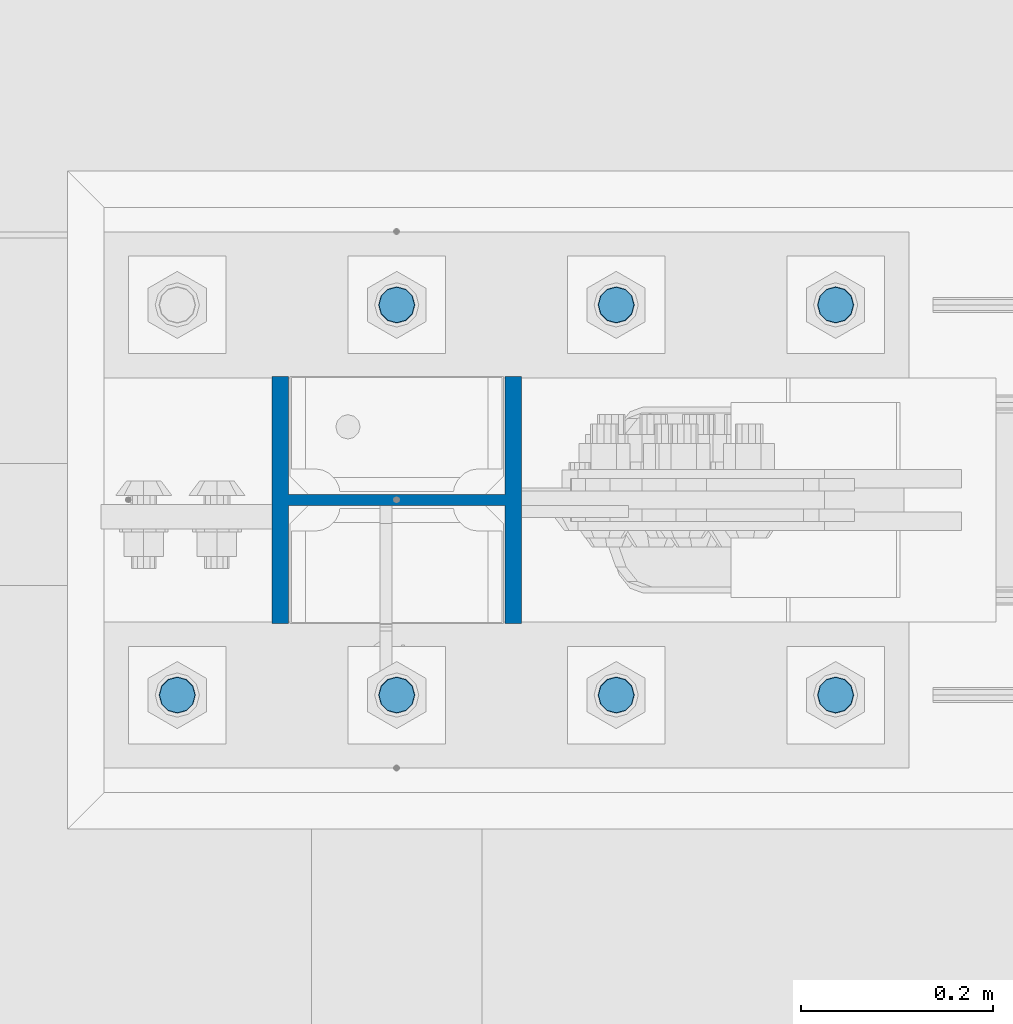
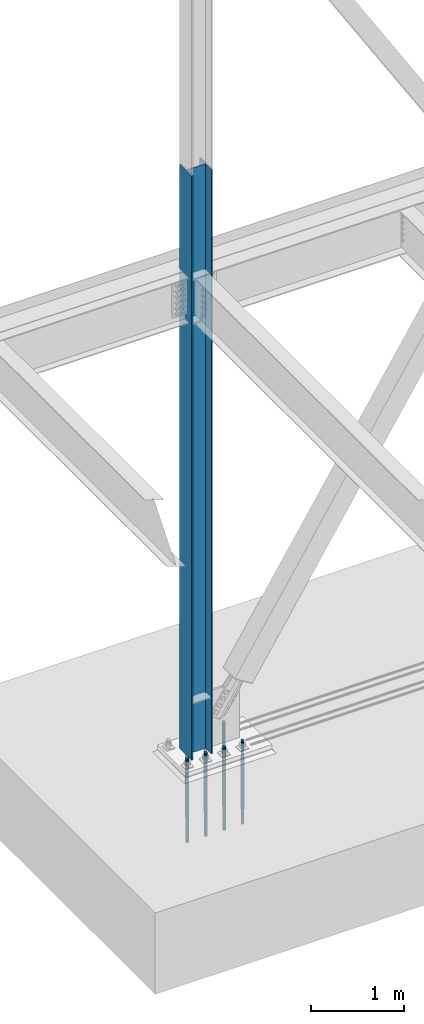
# One storey, part 1393 of 3843: 8 columns, 2 elements without a shape of their own.
"""IFC2X3 building model written with IfcOpenShell, lengths in millimetres."""

from ifc_helpers import new_model, si_unit, frame, origin_with_axes, place, context, subcontext, project, spatial, faceted_brep, material, type_object, element, aggregate, save


model = new_model("IFC2X3")

# Units and contexts
model_context = context("Model", 3, precision=1e-05, world=origin_with_axes())
body_context = subcontext(model_context, "Body", "Model", "MODEL_VIEW")
ifc_project = project(units=[si_unit("LENGTHUNIT", "METRE", prefix="MILLI"), si_unit("AREAUNIT", "SQUARE_METRE"), si_unit("VOLUMEUNIT", "CUBIC_METRE"), si_unit("MASSUNIT", "GRAM", prefix="KILO"), si_unit("TIMEUNIT", "SECOND"), si_unit("PLANEANGLEUNIT", "RADIAN"), si_unit("SOLIDANGLEUNIT", "STERADIAN"), si_unit("THERMODYNAMICTEMPERATUREUNIT", "DEGREE_CELSIUS"), si_unit("LUMINOUSINTENSITYUNIT", "LUMEN")], contexts=[model_context])

# Site, building, storey
site_placement = place(None, origin_with_axes())
site = spatial("IfcSite", under=ifc_project, at=site_placement, CompositionType="ELEMENT")
building_placement = place(site_placement, origin_with_axes())
building = spatial("IfcBuilding", under=site, at=building_placement, Name="Undefined", CompositionType="ELEMENT")
storey_placement = place(building_placement, origin_with_axes())
storey = spatial("IfcBuildingStorey", under=building, at=storey_placement, Name="Undefined", CompositionType="ELEMENT", Elevation=0.0)

# Assembly, column
assembly_1_placement = place(storey_placement, origin_with_axes())
assembly_1 = element("IfcElementAssembly", 1, at=assembly_1_placement, inside=storey, Name="COLUMN", AssemblyPlace="NOTDEFINED", PredefinedType="RIGID_FRAME")
ifc_material_1 = material(Name="STEEL/A992")
column_type_1 = type_object("IfcColumnType", Name="W10X60", PredefinedType="NOTDEFINED")
column_1_placement = place(assembly_1_placement, frame((22860.0, 104559.1, 30022.8), z_axis=(-1.0, 0.0, 0.0), x_axis=(0.0, 0.0, 1.0)))
column_1 = element("IfcColumn", 2, at=column_1_placement, type_object=column_type_1, material=ifc_material_1, Name="COLUMN", ObjectType="W10X60", context=body_context, shape_type="Brep", body=[
    faceted_brep([(101.599999999999, 128.587499999994, -130.174999999999), (101.599999999999, 128.587499999994, -112.712500000001), (7772.4, 128.587499999994, -112.712500000001), (7772.4, 128.587499999994, -130.174999999999), (101.599999999999, 5.55624999999418, -112.712500000001), (7772.4, 5.55624999999418, -112.712500000001), (101.599999999999, 5.55624999999418, 112.712500000001), (7772.4, 5.55624999999418, 112.712500000001), (101.599999999999, 128.587499999994, 112.712500000001), (7772.4, 128.587499999994, 112.712500000001), (101.599999999999, 128.587499999994, 130.174999999999), (7772.4, 128.587499999994, 130.174999999999), (101.599999999999, -128.587499999994, 130.174999999999), (7772.4, -128.587499999994, 130.174999999999), (101.599999999999, -128.587499999994, 112.712500000001), (7772.4, -128.587499999994, 112.712500000001), (101.599999999999, -5.55624999999418, 112.712500000001), (7772.4, -5.55624999999418, 112.712500000001), (101.599999999999, -5.55624999999418, -112.712500000001), (7772.4, -5.55624999999418, -112.712500000001), (101.599999999999, -128.587499999994, -112.712500000001), (7772.4, -128.587499999994, -112.712500000001), (101.599999999999, -128.587499999994, -130.174999999999), (7772.4, -128.587499999994, -130.174999999999)], [[[0, 1, 2, 3]], [[1, 4, 5, 2]], [[4, 6, 7, 5]], [[6, 8, 9, 7]], [[8, 10, 11, 9]], [[10, 12, 13, 11]], [[12, 14, 15, 13]], [[14, 16, 17, 15]], [[16, 18, 19, 17]], [[18, 20, 21, 19]], [[20, 22, 23, 21]], [[22, 0, 3, 23]], [[5, 7, 9, 11, 13, 15, 17, 19, 21, 23, 3, 2]], [[22, 20, 18, 16, 14, 12, 10, 8, 6, 4, 1, 0]]]),
])
aggregate(assembly_1, [column_1])

# Assembly, columns
assembly_2_placement = place(storey_placement, origin_with_axes())
assembly_2 = element("IfcElementAssembly", 3, at=assembly_2_placement, inside=storey, Name="TEMPLATE", AssemblyPlace="NOTDEFINED", PredefinedType="RIGID_FRAME")
ifc_material_2 = material(Name="Undefined/F1554-GR.55")
column_type_2 = type_object("IfcColumnType", PredefinedType="NOTDEFINED")
column_2_placement = place(assembly_2_placement, frame((23317.2, 104355.9, 30022.8), z_axis=(1.0, 0.0, 0.0), x_axis=(0.0, 0.0, -1.0)))
column_2 = element("IfcColumn", 4, at=column_2_placement, type_object=column_type_2, material=ifc_material_2, Name="ANCHOR_ROD", context=body_context, shape_type="Brep", body=[
    faceted_brep([(-209.549999999999, -16.0214699700155, 9.25), (-209.549999999999, -9.25, 16.0214699700118), (-209.549999999999, 0.0, 18.5), (-209.549999999999, 9.25, 16.0214699700118), (-209.549999999999, 16.0214699700155, 9.25), (-209.549999999999, 18.5, 0.0), (-209.549999999999, 16.0214699700155, -9.25), (-209.549999999999, 9.25, -16.0214699700118), (-209.549999999999, 0.0, -18.5), (-209.549999999999, -9.25, -16.0214699700118), (-209.549999999999, -16.0214699700155, -9.25), (-209.549999999999, -18.5, 0.0), (0.0, 18.5, 0.0), (0.0, 16.0214699700118, -9.25), (0.0, 9.25, -16.0214699700155), (0.0, 0.0, -18.5), (0.0, -9.25, -16.0214699700155), (0.0, -16.0214699700118, -9.25), (0.0, -18.5, 0.0), (0.0, -16.0214699700118, 9.25), (0.0, -9.25, 16.0214699700155), (0.0, 0.0, 18.5), (0.0, 9.25, 16.0214699700155), (0.0, 16.0214699700118, 9.25), (0.0, -16.4977839420972, 9.52500000000146), (0.0, -9.52500000000146, 16.4977839420972), (0.0, 0.0, 19.0499989999989), (0.0, 9.52500000000146, 16.4977839420972), (0.0, 16.4977839420972, 9.52500000000146), (0.0, 19.0500000000029, 0.0), (0.0, 16.4977839420972, -9.52500000000146), (0.0, 9.52500000000146, -16.4977839420972), (0.0, 0.0, -19.0499989999989), (0.0, -9.52500000000146, -16.4977839420972), (0.0, -16.4977839420972, -9.52500000000146), (0.0, -19.0500000000029, 0.0), (698.5, -19.0499999999993, 0.0), (698.5, -16.4977839420935, 9.52499999999418), (698.5, -9.52500000000146, 16.4977839420899), (698.5, 0.0, 19.0500000000029), (698.5, 9.52500000000146, 16.4977839420899), (698.5, 16.4977839420935, 9.52499999999418), (698.5, 19.0499999999993, 0.0), (698.5, 16.4977839420935, -9.52499999999418), (698.5, 9.52500000000146, -16.4977839420899), (698.5, 0.0, -19.0500000000029), (698.5, -9.52500000000146, -16.4977839420899), (698.5, -16.4977839420935, -9.52499999999418), (698.5, -9.25, 16.0214699700155), (698.5, 0.0, 18.5), (698.5, 9.25, 16.0214699700155), (698.5, 16.0214699700118, 9.25), (698.5, 18.5, 0.0), (698.5, 16.0214699700118, -9.25), (698.5, 9.25, -16.0214699700155), (698.5, 0.0, -18.5), (698.5, -9.25, -16.0214699700155), (698.5, -16.0214699700118, -9.25), (698.5, -18.5, 0.0), (698.5, -16.0214699700118, 9.25), (889.0, -9.25, -16.0214699700155), (889.0, 0.0, -18.5), (889.0, 9.25, -16.0214699700155), (889.0, 16.0214699700118, -9.25), (889.0, 18.5, 0.0), (889.0, 16.0214699700118, 9.25), (889.0, 9.25, 16.0214699700155), (889.0, 0.0, 18.5), (889.0, -9.25, 16.0214699700155), (889.0, -16.0214699700118, 9.25), (889.0, -18.5, 0.0), (889.0, -16.0214699700118, -9.25)], [[[0, 1, 2, 3, 4, 5, 6, 7, 8, 9, 10, 11]], [[6, 5, 12, 13]], [[7, 6, 13, 14]], [[8, 7, 14, 15]], [[9, 8, 15, 16]], [[10, 9, 16, 17]], [[11, 10, 17, 18]], [[0, 11, 18, 19]], [[1, 0, 19, 20]], [[2, 1, 20, 21]], [[3, 2, 21, 22]], [[4, 3, 22, 23]], [[5, 4, 23, 12]], [[24, 25, 26, 27, 28, 29, 30, 31, 32, 33, 34, 35], [22, 21, 20, 19, 18, 17, 16, 15, 14, 13, 12, 23]], [[24, 35, 36, 37]], [[25, 24, 37, 38]], [[26, 25, 38, 39]], [[27, 26, 39, 40]], [[28, 27, 40, 41]], [[29, 28, 41, 42]], [[30, 29, 42, 43]], [[31, 30, 43, 44]], [[32, 31, 44, 45]], [[33, 32, 45, 46]], [[34, 33, 46, 47]], [[35, 34, 47, 36]], [[46, 45, 44, 43, 42, 41, 40, 39, 38, 37, 36, 47], [48, 49, 50, 51, 52, 53, 54, 55, 56, 57, 58, 59]], [[60, 61, 62, 63, 64, 65, 66, 67, 68, 69, 70, 71]], [[68, 67, 49, 48]], [[69, 68, 48, 59]], [[70, 69, 59, 58]], [[71, 70, 58, 57]], [[60, 71, 57, 56]], [[61, 60, 56, 55]], [[62, 61, 55, 54]], [[63, 62, 54, 53]], [[64, 63, 53, 52]], [[65, 64, 52, 51]], [[66, 65, 51, 50]], [[67, 66, 50, 49]]]),
])
column_3_placement = place(assembly_2_placement, frame((23317.2, 104762.3, 30022.8), z_axis=(-1.0, 0.0, 0.0), x_axis=(0.0, 0.0, -1.0)))
column_3 = element("IfcColumn", 5, at=column_3_placement, type_object=column_type_2, material=ifc_material_2, Name="ANCHOR_ROD", context=body_context, shape_type="Brep", body=[
    faceted_brep([(-209.549999999999, -16.0214699700155, 9.25), (-209.549999999999, -9.25, 16.0214699700118), (-209.549999999999, 0.0, 18.5), (-209.549999999999, 9.25, 16.0214699700118), (-209.549999999999, 16.0214699700155, 9.25), (-209.549999999999, 18.5, 0.0), (-209.549999999999, 16.0214699700155, -9.25), (-209.549999999999, 9.25, -16.0214699700118), (-209.549999999999, 0.0, -18.5), (-209.549999999999, -9.25, -16.0214699700118), (-209.549999999999, -16.0214699700155, -9.25), (-209.549999999999, -18.5, 0.0), (0.0, 18.5, 0.0), (0.0, 16.0214699700118, -9.25), (0.0, 9.25, -16.0214699700155), (0.0, 0.0, -18.5), (0.0, -9.25, -16.0214699700155), (0.0, -16.0214699700118, -9.25), (0.0, -18.5, 0.0), (0.0, -16.0214699700118, 9.25), (0.0, -9.25, 16.0214699700155), (0.0, 0.0, 18.5), (0.0, 9.25, 16.0214699700155), (0.0, 16.0214699700118, 9.25), (0.0, -16.4977839420972, 9.52500000000146), (0.0, -9.52500000000146, 16.4977839420972), (0.0, 0.0, 19.0499989999989), (0.0, 9.52500000000146, 16.4977839420972), (0.0, 16.4977839420972, 9.52500000000146), (0.0, 19.0500000000029, 0.0), (0.0, 16.4977839420972, -9.52500000000146), (0.0, 9.52500000000146, -16.4977839420972), (0.0, 0.0, -19.0499989999989), (0.0, -9.52500000000146, -16.4977839420972), (0.0, -16.4977839420972, -9.52500000000146), (0.0, -19.0500000000029, 0.0), (698.5, -19.0499999999993, 0.0), (698.5, -16.4977839420935, 9.52499999999418), (698.5, -9.52500000000146, 16.4977839420899), (698.5, 0.0, 19.0500000000029), (698.5, 9.52500000000146, 16.4977839420899), (698.5, 16.4977839420935, 9.52499999999418), (698.5, 19.0499999999993, 0.0), (698.5, 16.4977839420935, -9.52499999999418), (698.5, 9.52500000000146, -16.4977839420899), (698.5, 0.0, -19.0500000000029), (698.5, -9.52500000000146, -16.4977839420899), (698.5, -16.4977839420935, -9.52499999999418), (698.5, -9.25, 16.0214699700155), (698.5, 0.0, 18.5), (698.5, 9.25, 16.0214699700155), (698.5, 16.0214699700118, 9.25), (698.5, 18.5, 0.0), (698.5, 16.0214699700118, -9.25), (698.5, 9.25, -16.0214699700155), (698.5, 0.0, -18.5), (698.5, -9.25, -16.0214699700155), (698.5, -16.0214699700118, -9.25), (698.5, -18.5, 0.0), (698.5, -16.0214699700118, 9.25), (889.0, -9.25, -16.0214699700155), (889.0, 0.0, -18.5), (889.0, 9.25, -16.0214699700155), (889.0, 16.0214699700118, -9.25), (889.0, 18.5, 0.0), (889.0, 16.0214699700118, 9.25), (889.0, 9.25, 16.0214699700155), (889.0, 0.0, 18.5), (889.0, -9.25, 16.0214699700155), (889.0, -16.0214699700118, 9.25), (889.0, -18.5, 0.0), (889.0, -16.0214699700118, -9.25)], [[[0, 1, 2, 3, 4, 5, 6, 7, 8, 9, 10, 11]], [[6, 5, 12, 13]], [[7, 6, 13, 14]], [[8, 7, 14, 15]], [[9, 8, 15, 16]], [[10, 9, 16, 17]], [[11, 10, 17, 18]], [[0, 11, 18, 19]], [[1, 0, 19, 20]], [[2, 1, 20, 21]], [[3, 2, 21, 22]], [[4, 3, 22, 23]], [[5, 4, 23, 12]], [[24, 25, 26, 27, 28, 29, 30, 31, 32, 33, 34, 35], [22, 21, 20, 19, 18, 17, 16, 15, 14, 13, 12, 23]], [[24, 35, 36, 37]], [[25, 24, 37, 38]], [[26, 25, 38, 39]], [[27, 26, 39, 40]], [[28, 27, 40, 41]], [[29, 28, 41, 42]], [[30, 29, 42, 43]], [[31, 30, 43, 44]], [[32, 31, 44, 45]], [[33, 32, 45, 46]], [[34, 33, 46, 47]], [[35, 34, 47, 36]], [[46, 45, 44, 43, 42, 41, 40, 39, 38, 37, 36, 47], [48, 49, 50, 51, 52, 53, 54, 55, 56, 57, 58, 59]], [[60, 61, 62, 63, 64, 65, 66, 67, 68, 69, 70, 71]], [[68, 67, 49, 48]], [[69, 68, 48, 59]], [[70, 69, 59, 58]], [[71, 70, 58, 57]], [[60, 71, 57, 56]], [[61, 60, 56, 55]], [[62, 61, 55, 54]], [[63, 62, 54, 53]], [[64, 63, 53, 52]], [[65, 64, 52, 51]], [[66, 65, 51, 50]], [[67, 66, 50, 49]]]),
])
column_4_placement = place(assembly_2_placement, frame((23088.6, 104355.9, 30022.8), z_axis=(1.0, 0.0, 0.0), x_axis=(0.0, 0.0, -1.0)))
column_4 = element("IfcColumn", 6, at=column_4_placement, type_object=column_type_2, material=ifc_material_2, Name="ANCHOR_ROD", context=body_context, shape_type="Brep", body=[
    faceted_brep([(-209.549999999999, -16.0214699700155, 9.25), (-209.549999999999, -9.25, 16.0214699700118), (-209.549999999999, 0.0, 18.5), (-209.549999999999, 9.25, 16.0214699700118), (-209.549999999999, 16.0214699700155, 9.25), (-209.549999999999, 18.5, 0.0), (-209.549999999999, 16.0214699700155, -9.25), (-209.549999999999, 9.25, -16.0214699700118), (-209.549999999999, 0.0, -18.5), (-209.549999999999, -9.25, -16.0214699700118), (-209.549999999999, -16.0214699700155, -9.25), (-209.549999999999, -18.5, 0.0), (0.0, 18.5, 0.0), (0.0, 16.0214699700118, -9.25), (0.0, 9.25, -16.0214699700155), (0.0, 0.0, -18.5), (0.0, -9.25, -16.0214699700155), (0.0, -16.0214699700118, -9.25), (0.0, -18.5, 0.0), (0.0, -16.0214699700118, 9.25), (0.0, -9.25, 16.0214699700155), (0.0, 0.0, 18.5), (0.0, 9.25, 16.0214699700155), (0.0, 16.0214699700118, 9.25), (0.0, -16.4977839420972, 9.52500000000146), (0.0, -9.52500000000146, 16.4977839420972), (0.0, 0.0, 19.0499989999989), (0.0, 9.52500000000146, 16.4977839420972), (0.0, 16.4977839420972, 9.52500000000146), (0.0, 19.0500000000029, 0.0), (0.0, 16.4977839420972, -9.52500000000146), (0.0, 9.52500000000146, -16.4977839420972), (0.0, 0.0, -19.0499989999989), (0.0, -9.52500000000146, -16.4977839420972), (0.0, -16.4977839420972, -9.52500000000146), (0.0, -19.0500000000029, 0.0), (698.5, -19.0499999999993, 0.0), (698.5, -16.4977839420935, 9.52499999999418), (698.5, -9.52500000000146, 16.4977839420899), (698.5, 0.0, 19.0500000000029), (698.5, 9.52500000000146, 16.4977839420899), (698.5, 16.4977839420935, 9.52499999999418), (698.5, 19.0499999999993, 0.0), (698.5, 16.4977839420935, -9.52499999999418), (698.5, 9.52500000000146, -16.4977839420899), (698.5, 0.0, -19.0500000000029), (698.5, -9.52500000000146, -16.4977839420899), (698.5, -16.4977839420935, -9.52499999999418), (698.5, -9.25, 16.0214699700155), (698.5, 0.0, 18.5), (698.5, 9.25, 16.0214699700155), (698.5, 16.0214699700118, 9.25), (698.5, 18.5, 0.0), (698.5, 16.0214699700118, -9.25), (698.5, 9.25, -16.0214699700155), (698.5, 0.0, -18.5), (698.5, -9.25, -16.0214699700155), (698.5, -16.0214699700118, -9.25), (698.5, -18.5, 0.0), (698.5, -16.0214699700118, 9.25), (889.0, -9.25, -16.0214699700155), (889.0, 0.0, -18.5), (889.0, 9.25, -16.0214699700155), (889.0, 16.0214699700118, -9.25), (889.0, 18.5, 0.0), (889.0, 16.0214699700118, 9.25), (889.0, 9.25, 16.0214699700155), (889.0, 0.0, 18.5), (889.0, -9.25, 16.0214699700155), (889.0, -16.0214699700118, 9.25), (889.0, -18.5, 0.0), (889.0, -16.0214699700118, -9.25)], [[[0, 1, 2, 3, 4, 5, 6, 7, 8, 9, 10, 11]], [[6, 5, 12, 13]], [[7, 6, 13, 14]], [[8, 7, 14, 15]], [[9, 8, 15, 16]], [[10, 9, 16, 17]], [[11, 10, 17, 18]], [[0, 11, 18, 19]], [[1, 0, 19, 20]], [[2, 1, 20, 21]], [[3, 2, 21, 22]], [[4, 3, 22, 23]], [[5, 4, 23, 12]], [[24, 25, 26, 27, 28, 29, 30, 31, 32, 33, 34, 35], [22, 21, 20, 19, 18, 17, 16, 15, 14, 13, 12, 23]], [[24, 35, 36, 37]], [[25, 24, 37, 38]], [[26, 25, 38, 39]], [[27, 26, 39, 40]], [[28, 27, 40, 41]], [[29, 28, 41, 42]], [[30, 29, 42, 43]], [[31, 30, 43, 44]], [[32, 31, 44, 45]], [[33, 32, 45, 46]], [[34, 33, 46, 47]], [[35, 34, 47, 36]], [[46, 45, 44, 43, 42, 41, 40, 39, 38, 37, 36, 47], [48, 49, 50, 51, 52, 53, 54, 55, 56, 57, 58, 59]], [[60, 61, 62, 63, 64, 65, 66, 67, 68, 69, 70, 71]], [[68, 67, 49, 48]], [[69, 68, 48, 59]], [[70, 69, 59, 58]], [[71, 70, 58, 57]], [[60, 71, 57, 56]], [[61, 60, 56, 55]], [[62, 61, 55, 54]], [[63, 62, 54, 53]], [[64, 63, 53, 52]], [[65, 64, 52, 51]], [[66, 65, 51, 50]], [[67, 66, 50, 49]]]),
])
column_5_placement = place(assembly_2_placement, frame((23088.6, 104762.3, 30022.8), z_axis=(-1.0, 0.0, 0.0), x_axis=(0.0, 0.0, -1.0)))
column_5 = element("IfcColumn", 7, at=column_5_placement, type_object=column_type_2, material=ifc_material_2, Name="ANCHOR_ROD", context=body_context, shape_type="Brep", body=[
    faceted_brep([(-209.549999999999, -16.0214699700155, 9.25), (-209.549999999999, -9.25, 16.0214699700118), (-209.549999999999, 0.0, 18.5), (-209.549999999999, 9.25, 16.0214699700118), (-209.549999999999, 16.0214699700155, 9.25), (-209.549999999999, 18.5, 0.0), (-209.549999999999, 16.0214699700155, -9.25), (-209.549999999999, 9.25, -16.0214699700118), (-209.549999999999, 0.0, -18.5), (-209.549999999999, -9.25, -16.0214699700118), (-209.549999999999, -16.0214699700155, -9.25), (-209.549999999999, -18.5, 0.0), (0.0, 18.5, 0.0), (0.0, 16.0214699700118, -9.25), (0.0, 9.25, -16.0214699700155), (0.0, 0.0, -18.5), (0.0, -9.25, -16.0214699700155), (0.0, -16.0214699700118, -9.25), (0.0, -18.5, 0.0), (0.0, -16.0214699700118, 9.25), (0.0, -9.25, 16.0214699700155), (0.0, 0.0, 18.5), (0.0, 9.25, 16.0214699700155), (0.0, 16.0214699700118, 9.25), (0.0, -16.4977839420972, 9.52500000000146), (0.0, -9.52500000000146, 16.4977839420972), (0.0, 0.0, 19.0499989999989), (0.0, 9.52500000000146, 16.4977839420972), (0.0, 16.4977839420972, 9.52500000000146), (0.0, 19.0500000000029, 0.0), (0.0, 16.4977839420972, -9.52500000000146), (0.0, 9.52500000000146, -16.4977839420972), (0.0, 0.0, -19.0499989999989), (0.0, -9.52500000000146, -16.4977839420972), (0.0, -16.4977839420972, -9.52500000000146), (0.0, -19.0500000000029, 0.0), (698.5, -19.0499999999993, 0.0), (698.5, -16.4977839420935, 9.52499999999418), (698.5, -9.52500000000146, 16.4977839420899), (698.5, 0.0, 19.0500000000029), (698.5, 9.52500000000146, 16.4977839420899), (698.5, 16.4977839420935, 9.52499999999418), (698.5, 19.0499999999993, 0.0), (698.5, 16.4977839420935, -9.52499999999418), (698.5, 9.52500000000146, -16.4977839420899), (698.5, 0.0, -19.0500000000029), (698.5, -9.52500000000146, -16.4977839420899), (698.5, -16.4977839420935, -9.52499999999418), (698.5, -9.25, 16.0214699700155), (698.5, 0.0, 18.5), (698.5, 9.25, 16.0214699700155), (698.5, 16.0214699700118, 9.25), (698.5, 18.5, 0.0), (698.5, 16.0214699700118, -9.25), (698.5, 9.25, -16.0214699700155), (698.5, 0.0, -18.5), (698.5, -9.25, -16.0214699700155), (698.5, -16.0214699700118, -9.25), (698.5, -18.5, 0.0), (698.5, -16.0214699700118, 9.25), (889.0, -9.25, -16.0214699700155), (889.0, 0.0, -18.5), (889.0, 9.25, -16.0214699700155), (889.0, 16.0214699700118, -9.25), (889.0, 18.5, 0.0), (889.0, 16.0214699700118, 9.25), (889.0, 9.25, 16.0214699700155), (889.0, 0.0, 18.5), (889.0, -9.25, 16.0214699700155), (889.0, -16.0214699700118, 9.25), (889.0, -18.5, 0.0), (889.0, -16.0214699700118, -9.25)], [[[0, 1, 2, 3, 4, 5, 6, 7, 8, 9, 10, 11]], [[6, 5, 12, 13]], [[7, 6, 13, 14]], [[8, 7, 14, 15]], [[9, 8, 15, 16]], [[10, 9, 16, 17]], [[11, 10, 17, 18]], [[0, 11, 18, 19]], [[1, 0, 19, 20]], [[2, 1, 20, 21]], [[3, 2, 21, 22]], [[4, 3, 22, 23]], [[5, 4, 23, 12]], [[24, 25, 26, 27, 28, 29, 30, 31, 32, 33, 34, 35], [22, 21, 20, 19, 18, 17, 16, 15, 14, 13, 12, 23]], [[24, 35, 36, 37]], [[25, 24, 37, 38]], [[26, 25, 38, 39]], [[27, 26, 39, 40]], [[28, 27, 40, 41]], [[29, 28, 41, 42]], [[30, 29, 42, 43]], [[31, 30, 43, 44]], [[32, 31, 44, 45]], [[33, 32, 45, 46]], [[34, 33, 46, 47]], [[35, 34, 47, 36]], [[46, 45, 44, 43, 42, 41, 40, 39, 38, 37, 36, 47], [48, 49, 50, 51, 52, 53, 54, 55, 56, 57, 58, 59]], [[60, 61, 62, 63, 64, 65, 66, 67, 68, 69, 70, 71]], [[68, 67, 49, 48]], [[69, 68, 48, 59]], [[70, 69, 59, 58]], [[71, 70, 58, 57]], [[60, 71, 57, 56]], [[61, 60, 56, 55]], [[62, 61, 55, 54]], [[63, 62, 54, 53]], [[64, 63, 53, 52]], [[65, 64, 52, 51]], [[66, 65, 51, 50]], [[67, 66, 50, 49]]]),
])
column_6_placement = place(assembly_2_placement, frame((22860.0, 104355.9, 30022.8), z_axis=(1.0, 0.0, 0.0), x_axis=(0.0, 0.0, -1.0)))
column_6 = element("IfcColumn", 8, at=column_6_placement, type_object=column_type_2, material=ifc_material_2, Name="ANCHOR_ROD", context=body_context, shape_type="Brep", body=[
    faceted_brep([(-209.549999999999, -16.0214699700155, 9.25), (-209.549999999999, -9.25, 16.0214699700118), (-209.549999999999, 0.0, 18.5), (-209.549999999999, 9.25, 16.0214699700118), (-209.549999999999, 16.0214699700155, 9.25), (-209.549999999999, 18.5, 0.0), (-209.549999999999, 16.0214699700155, -9.25), (-209.549999999999, 9.25, -16.0214699700118), (-209.549999999999, 0.0, -18.5), (-209.549999999999, -9.25, -16.0214699700118), (-209.549999999999, -16.0214699700155, -9.25), (-209.549999999999, -18.5, 0.0), (0.0, 18.5, 0.0), (0.0, 16.0214699700118, -9.25), (0.0, 9.25, -16.0214699700155), (0.0, 0.0, -18.5), (0.0, -9.25, -16.0214699700155), (0.0, -16.0214699700118, -9.25), (0.0, -18.5, 0.0), (0.0, -16.0214699700118, 9.25), (0.0, -9.25, 16.0214699700155), (0.0, 0.0, 18.5), (0.0, 9.25, 16.0214699700155), (0.0, 16.0214699700118, 9.25), (0.0, -16.4977839420972, 9.52500000000146), (0.0, -9.52500000000146, 16.4977839420972), (0.0, 0.0, 19.0499989999989), (0.0, 9.52500000000146, 16.4977839420972), (0.0, 16.4977839420972, 9.52500000000146), (0.0, 19.0500000000029, 0.0), (0.0, 16.4977839420972, -9.52500000000146), (0.0, 9.52500000000146, -16.4977839420972), (0.0, 0.0, -19.0499989999989), (0.0, -9.52500000000146, -16.4977839420972), (0.0, -16.4977839420972, -9.52500000000146), (0.0, -19.0500000000029, 0.0), (698.5, -19.0499999999993, 0.0), (698.5, -16.4977839420935, 9.52499999999418), (698.5, -9.52500000000146, 16.4977839420899), (698.5, 0.0, 19.0500000000029), (698.5, 9.52500000000146, 16.4977839420899), (698.5, 16.4977839420935, 9.52499999999418), (698.5, 19.0499999999993, 0.0), (698.5, 16.4977839420935, -9.52499999999418), (698.5, 9.52500000000146, -16.4977839420899), (698.5, 0.0, -19.0500000000029), (698.5, -9.52500000000146, -16.4977839420899), (698.5, -16.4977839420935, -9.52499999999418), (698.5, -9.25, 16.0214699700155), (698.5, 0.0, 18.5), (698.5, 9.25, 16.0214699700155), (698.5, 16.0214699700118, 9.25), (698.5, 18.5, 0.0), (698.5, 16.0214699700118, -9.25), (698.5, 9.25, -16.0214699700155), (698.5, 0.0, -18.5), (698.5, -9.25, -16.0214699700155), (698.5, -16.0214699700118, -9.25), (698.5, -18.5, 0.0), (698.5, -16.0214699700118, 9.25), (889.0, -9.25, -16.0214699700155), (889.0, 0.0, -18.5), (889.0, 9.25, -16.0214699700155), (889.0, 16.0214699700118, -9.25), (889.0, 18.5, 0.0), (889.0, 16.0214699700118, 9.25), (889.0, 9.25, 16.0214699700155), (889.0, 0.0, 18.5), (889.0, -9.25, 16.0214699700155), (889.0, -16.0214699700118, 9.25), (889.0, -18.5, 0.0), (889.0, -16.0214699700118, -9.25)], [[[0, 1, 2, 3, 4, 5, 6, 7, 8, 9, 10, 11]], [[6, 5, 12, 13]], [[7, 6, 13, 14]], [[8, 7, 14, 15]], [[9, 8, 15, 16]], [[10, 9, 16, 17]], [[11, 10, 17, 18]], [[0, 11, 18, 19]], [[1, 0, 19, 20]], [[2, 1, 20, 21]], [[3, 2, 21, 22]], [[4, 3, 22, 23]], [[5, 4, 23, 12]], [[24, 25, 26, 27, 28, 29, 30, 31, 32, 33, 34, 35], [22, 21, 20, 19, 18, 17, 16, 15, 14, 13, 12, 23]], [[24, 35, 36, 37]], [[25, 24, 37, 38]], [[26, 25, 38, 39]], [[27, 26, 39, 40]], [[28, 27, 40, 41]], [[29, 28, 41, 42]], [[30, 29, 42, 43]], [[31, 30, 43, 44]], [[32, 31, 44, 45]], [[33, 32, 45, 46]], [[34, 33, 46, 47]], [[35, 34, 47, 36]], [[46, 45, 44, 43, 42, 41, 40, 39, 38, 37, 36, 47], [48, 49, 50, 51, 52, 53, 54, 55, 56, 57, 58, 59]], [[60, 61, 62, 63, 64, 65, 66, 67, 68, 69, 70, 71]], [[68, 67, 49, 48]], [[69, 68, 48, 59]], [[70, 69, 59, 58]], [[71, 70, 58, 57]], [[60, 71, 57, 56]], [[61, 60, 56, 55]], [[62, 61, 55, 54]], [[63, 62, 54, 53]], [[64, 63, 53, 52]], [[65, 64, 52, 51]], [[66, 65, 51, 50]], [[67, 66, 50, 49]]]),
])
column_7_placement = place(assembly_2_placement, frame((22860.0, 104762.3, 30022.8), z_axis=(-1.0, 0.0, 0.0), x_axis=(0.0, 0.0, -1.0)))
column_7 = element("IfcColumn", 9, at=column_7_placement, type_object=column_type_2, material=ifc_material_2, Name="ANCHOR_ROD", context=body_context, shape_type="Brep", body=[
    faceted_brep([(-209.549999999999, -16.0214699700155, 9.25), (-209.549999999999, -9.25, 16.0214699700118), (-209.549999999999, 0.0, 18.5), (-209.549999999999, 9.25, 16.0214699700118), (-209.549999999999, 16.0214699700155, 9.25), (-209.549999999999, 18.5, 0.0), (-209.549999999999, 16.0214699700155, -9.25), (-209.549999999999, 9.25, -16.0214699700118), (-209.549999999999, 0.0, -18.5), (-209.549999999999, -9.25, -16.0214699700118), (-209.549999999999, -16.0214699700155, -9.25), (-209.549999999999, -18.5, 0.0), (0.0, 18.5, 0.0), (0.0, 16.0214699700118, -9.25), (0.0, 9.25, -16.0214699700155), (0.0, 0.0, -18.5), (0.0, -9.25, -16.0214699700155), (0.0, -16.0214699700118, -9.25), (0.0, -18.5, 0.0), (0.0, -16.0214699700118, 9.25), (0.0, -9.25, 16.0214699700155), (0.0, 0.0, 18.5), (0.0, 9.25, 16.0214699700155), (0.0, 16.0214699700118, 9.25), (0.0, -16.4977839420972, 9.52500000000146), (0.0, -9.52500000000146, 16.4977839420972), (0.0, 0.0, 19.0499989999989), (0.0, 9.52500000000146, 16.4977839420972), (0.0, 16.4977839420972, 9.52500000000146), (0.0, 19.0500000000029, 0.0), (0.0, 16.4977839420972, -9.52500000000146), (0.0, 9.52500000000146, -16.4977839420972), (0.0, 0.0, -19.0499989999989), (0.0, -9.52500000000146, -16.4977839420972), (0.0, -16.4977839420972, -9.52500000000146), (0.0, -19.0500000000029, 0.0), (698.5, -19.0499999999993, 0.0), (698.5, -16.4977839420935, 9.52499999999418), (698.5, -9.52500000000146, 16.4977839420899), (698.5, 0.0, 19.0500000000029), (698.5, 9.52500000000146, 16.4977839420899), (698.5, 16.4977839420935, 9.52499999999418), (698.5, 19.0499999999993, 0.0), (698.5, 16.4977839420935, -9.52499999999418), (698.5, 9.52500000000146, -16.4977839420899), (698.5, 0.0, -19.0500000000029), (698.5, -9.52500000000146, -16.4977839420899), (698.5, -16.4977839420935, -9.52499999999418), (698.5, -9.25, 16.0214699700155), (698.5, 0.0, 18.5), (698.5, 9.25, 16.0214699700155), (698.5, 16.0214699700118, 9.25), (698.5, 18.5, 0.0), (698.5, 16.0214699700118, -9.25), (698.5, 9.25, -16.0214699700155), (698.5, 0.0, -18.5), (698.5, -9.25, -16.0214699700155), (698.5, -16.0214699700118, -9.25), (698.5, -18.5, 0.0), (698.5, -16.0214699700118, 9.25), (889.0, -9.25, -16.0214699700155), (889.0, 0.0, -18.5), (889.0, 9.25, -16.0214699700155), (889.0, 16.0214699700118, -9.25), (889.0, 18.5, 0.0), (889.0, 16.0214699700118, 9.25), (889.0, 9.25, 16.0214699700155), (889.0, 0.0, 18.5), (889.0, -9.25, 16.0214699700155), (889.0, -16.0214699700118, 9.25), (889.0, -18.5, 0.0), (889.0, -16.0214699700118, -9.25)], [[[0, 1, 2, 3, 4, 5, 6, 7, 8, 9, 10, 11]], [[6, 5, 12, 13]], [[7, 6, 13, 14]], [[8, 7, 14, 15]], [[9, 8, 15, 16]], [[10, 9, 16, 17]], [[11, 10, 17, 18]], [[0, 11, 18, 19]], [[1, 0, 19, 20]], [[2, 1, 20, 21]], [[3, 2, 21, 22]], [[4, 3, 22, 23]], [[5, 4, 23, 12]], [[24, 25, 26, 27, 28, 29, 30, 31, 32, 33, 34, 35], [22, 21, 20, 19, 18, 17, 16, 15, 14, 13, 12, 23]], [[24, 35, 36, 37]], [[25, 24, 37, 38]], [[26, 25, 38, 39]], [[27, 26, 39, 40]], [[28, 27, 40, 41]], [[29, 28, 41, 42]], [[30, 29, 42, 43]], [[31, 30, 43, 44]], [[32, 31, 44, 45]], [[33, 32, 45, 46]], [[34, 33, 46, 47]], [[35, 34, 47, 36]], [[46, 45, 44, 43, 42, 41, 40, 39, 38, 37, 36, 47], [48, 49, 50, 51, 52, 53, 54, 55, 56, 57, 58, 59]], [[60, 61, 62, 63, 64, 65, 66, 67, 68, 69, 70, 71]], [[68, 67, 49, 48]], [[69, 68, 48, 59]], [[70, 69, 59, 58]], [[71, 70, 58, 57]], [[60, 71, 57, 56]], [[61, 60, 56, 55]], [[62, 61, 55, 54]], [[63, 62, 54, 53]], [[64, 63, 53, 52]], [[65, 64, 52, 51]], [[66, 65, 51, 50]], [[67, 66, 50, 49]]]),
])
column_8_placement = place(assembly_2_placement, frame((22631.4, 104355.9, 30022.8), z_axis=(1.0, 0.0, 0.0), x_axis=(0.0, 0.0, -1.0)))
column_8 = element("IfcColumn", 10, at=column_8_placement, type_object=column_type_2, material=ifc_material_2, Name="ANCHOR_ROD", context=body_context, shape_type="Brep", body=[
    faceted_brep([(-209.549999999999, -16.0214699700155, 9.25), (-209.549999999999, -9.25, 16.0214699700118), (-209.549999999999, 0.0, 18.5), (-209.549999999999, 9.25, 16.0214699700118), (-209.549999999999, 16.0214699700155, 9.25), (-209.549999999999, 18.5, 0.0), (-209.549999999999, 16.0214699700155, -9.25), (-209.549999999999, 9.25, -16.0214699700118), (-209.549999999999, 0.0, -18.5), (-209.549999999999, -9.25, -16.0214699700118), (-209.549999999999, -16.0214699700155, -9.25), (-209.549999999999, -18.5, 0.0), (0.0, 18.5, 0.0), (0.0, 16.0214699700118, -9.25), (0.0, 9.25, -16.0214699700155), (0.0, 0.0, -18.5), (0.0, -9.25, -16.0214699700155), (0.0, -16.0214699700118, -9.25), (0.0, -18.5, 0.0), (0.0, -16.0214699700118, 9.25), (0.0, -9.25, 16.0214699700155), (0.0, 0.0, 18.5), (0.0, 9.25, 16.0214699700155), (0.0, 16.0214699700118, 9.25), (0.0, -16.4977839420972, 9.52500000000146), (0.0, -9.52500000000146, 16.4977839420972), (0.0, 0.0, 19.0499989999989), (0.0, 9.52500000000146, 16.4977839420972), (0.0, 16.4977839420972, 9.52500000000146), (0.0, 19.0500000000029, 0.0), (0.0, 16.4977839420972, -9.52500000000146), (0.0, 9.52500000000146, -16.4977839420972), (0.0, 0.0, -19.0499989999989), (0.0, -9.52500000000146, -16.4977839420972), (0.0, -16.4977839420972, -9.52500000000146), (0.0, -19.0500000000029, 0.0), (698.5, -19.0499999999993, 0.0), (698.5, -16.4977839420935, 9.52499999999418), (698.5, -9.52500000000146, 16.4977839420899), (698.5, 0.0, 19.0500000000029), (698.5, 9.52500000000146, 16.4977839420899), (698.5, 16.4977839420935, 9.52499999999418), (698.5, 19.0499999999993, 0.0), (698.5, 16.4977839420935, -9.52499999999418), (698.5, 9.52500000000146, -16.4977839420899), (698.5, 0.0, -19.0500000000029), (698.5, -9.52500000000146, -16.4977839420899), (698.5, -16.4977839420935, -9.52499999999418), (698.5, -9.25, 16.0214699700155), (698.5, 0.0, 18.5), (698.5, 9.25, 16.0214699700155), (698.5, 16.0214699700118, 9.25), (698.5, 18.5, 0.0), (698.5, 16.0214699700118, -9.25), (698.5, 9.25, -16.0214699700155), (698.5, 0.0, -18.5), (698.5, -9.25, -16.0214699700155), (698.5, -16.0214699700118, -9.25), (698.5, -18.5, 0.0), (698.5, -16.0214699700118, 9.25), (889.0, -9.25, -16.0214699700155), (889.0, 0.0, -18.5), (889.0, 9.25, -16.0214699700155), (889.0, 16.0214699700118, -9.25), (889.0, 18.5, 0.0), (889.0, 16.0214699700118, 9.25), (889.0, 9.25, 16.0214699700155), (889.0, 0.0, 18.5), (889.0, -9.25, 16.0214699700155), (889.0, -16.0214699700118, 9.25), (889.0, -18.5, 0.0), (889.0, -16.0214699700118, -9.25)], [[[0, 1, 2, 3, 4, 5, 6, 7, 8, 9, 10, 11]], [[6, 5, 12, 13]], [[7, 6, 13, 14]], [[8, 7, 14, 15]], [[9, 8, 15, 16]], [[10, 9, 16, 17]], [[11, 10, 17, 18]], [[0, 11, 18, 19]], [[1, 0, 19, 20]], [[2, 1, 20, 21]], [[3, 2, 21, 22]], [[4, 3, 22, 23]], [[5, 4, 23, 12]], [[24, 25, 26, 27, 28, 29, 30, 31, 32, 33, 34, 35], [22, 21, 20, 19, 18, 17, 16, 15, 14, 13, 12, 23]], [[24, 35, 36, 37]], [[25, 24, 37, 38]], [[26, 25, 38, 39]], [[27, 26, 39, 40]], [[28, 27, 40, 41]], [[29, 28, 41, 42]], [[30, 29, 42, 43]], [[31, 30, 43, 44]], [[32, 31, 44, 45]], [[33, 32, 45, 46]], [[34, 33, 46, 47]], [[35, 34, 47, 36]], [[46, 45, 44, 43, 42, 41, 40, 39, 38, 37, 36, 47], [48, 49, 50, 51, 52, 53, 54, 55, 56, 57, 58, 59]], [[60, 61, 62, 63, 64, 65, 66, 67, 68, 69, 70, 71]], [[68, 67, 49, 48]], [[69, 68, 48, 59]], [[70, 69, 59, 58]], [[71, 70, 58, 57]], [[60, 71, 57, 56]], [[61, 60, 56, 55]], [[62, 61, 55, 54]], [[63, 62, 54, 53]], [[64, 63, 53, 52]], [[65, 64, 52, 51]], [[66, 65, 51, 50]], [[67, 66, 50, 49]]]),
])
aggregate(assembly_2, [column_2, column_3, column_4, column_5, column_6, column_7, column_8])

save(model, "model.ifc")
